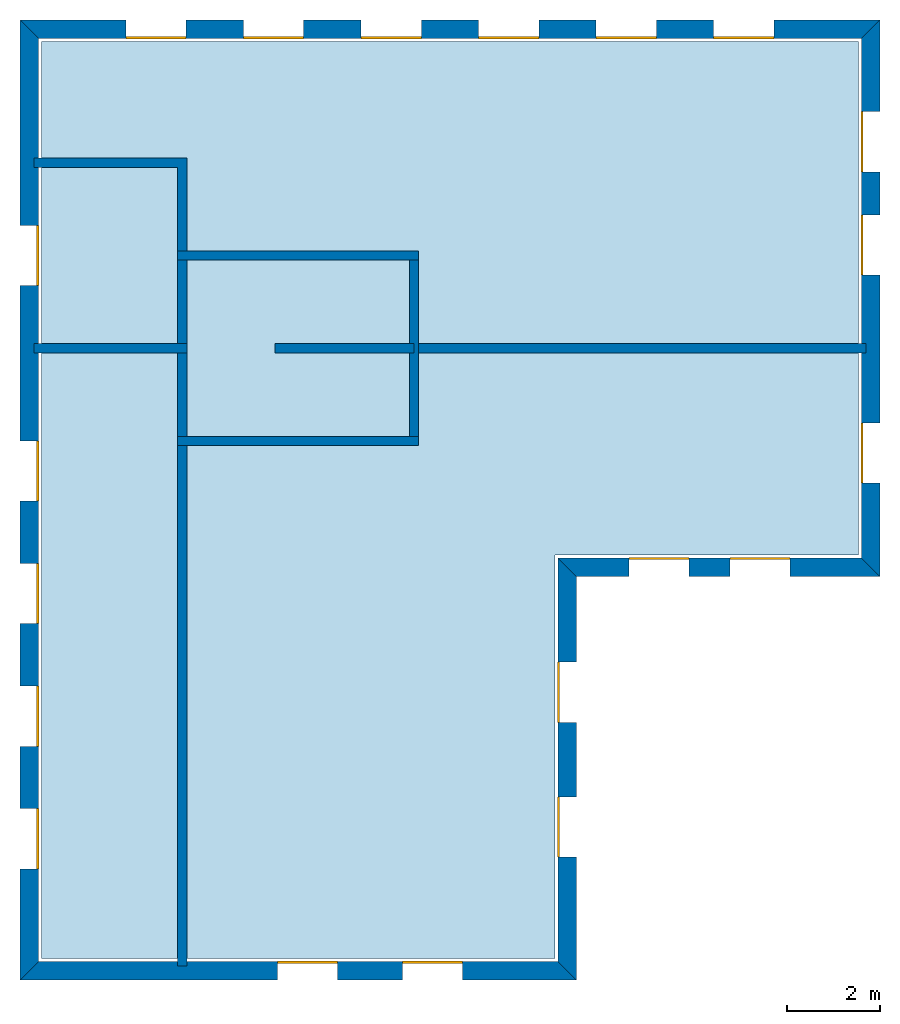
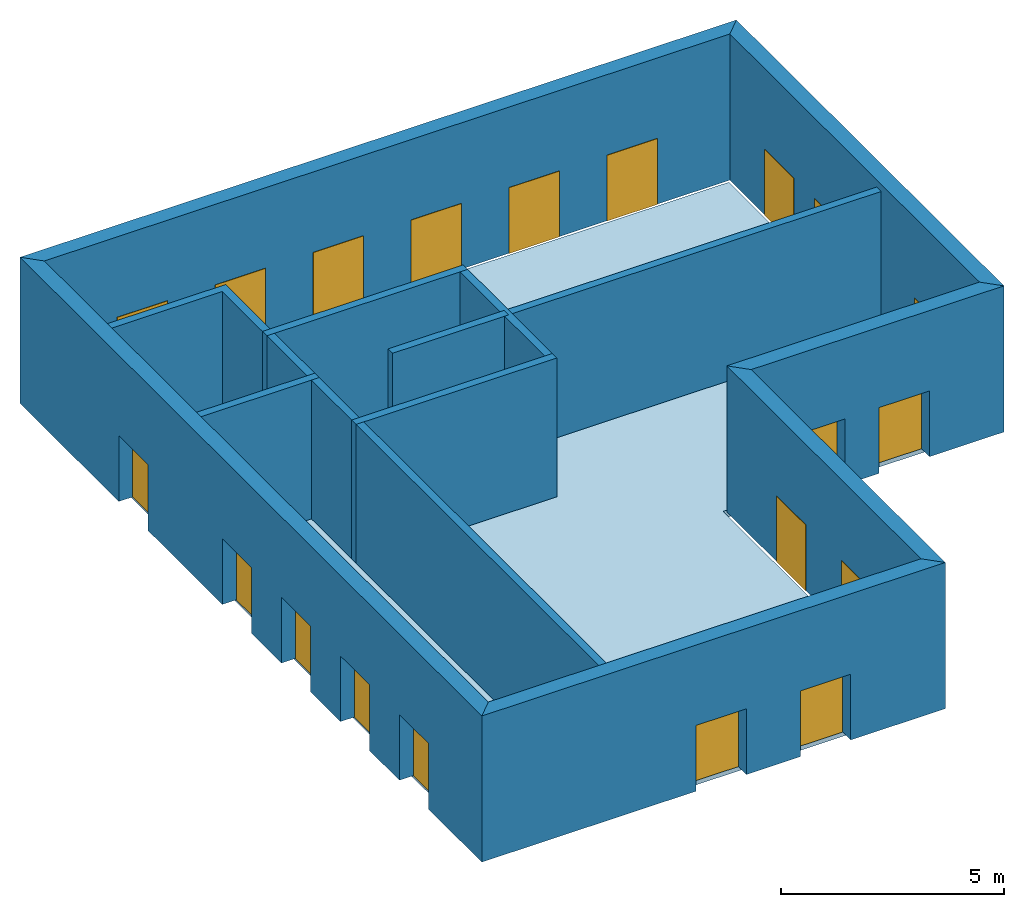
# One storey: 20 windows, 15 walls, 1 slab, 20 openings.
"""IFC4 building model written with IfcOpenShell, lengths in metres."""

from ifc_helpers import new_model, si_unit, origin_with_axes, place, context, subcontext, project, spatial, line, indexed_curve, outline, extrude, element, fill, save


model = new_model("IFC4")

# Units and contexts
model_context = context("Model", 3, precision=1e-05, world=origin_with_axes())
body_context = subcontext(model_context, "Body", "Model", "MODEL_VIEW")
ifc_project = project(units=[si_unit("AREAUNIT", "SQUARE_METRE"), si_unit("VOLUMEUNIT", "CUBIC_METRE"), si_unit("LENGTHUNIT", "METRE")], contexts=[model_context])

# Site, building, storey
site = spatial("IfcSite", under=ifc_project)
building = spatial("IfcBuilding", under=site, Name="Building 1")
storey_placement = place(None, origin_with_axes())
storey = spatial("IfcBuildingStorey", under=building, at=storey_placement, Name="01 Storey")

# Slab
slab_placement = place(storey_placement, origin_with_axes())
element("IfcSlab", 1, at=slab_placement, inside=storey, Name="Slab", context=body_context, shape_type="SweptSolid", body=[
    extrude(outline(indexed_curve([(15.533354, 14.715575), (22.079464, 14.715575), (22.079464, 25.795575), (4.453354, 25.795575), (4.453354, 6.0082), (15.533354, 6.0082)], segments=[line(1, 2), line(2, 3), line(3, 4), line(4, 5), line(5, 6)])), origin_with_axes(), (0.0, 0.0, -1.0), 0.2),
])

# Walls
wall_1_placement = place(storey_placement, origin_with_axes())
element("IfcWall", 2, at=wall_1_placement, inside=storey, Name="Wall", context=body_context, shape_type="SweptSolid", body=[
    extrude(outline(indexed_curve([(22.239464, 19.274943), (12.393354, 19.274943), (12.393354, 19.074943), (22.239464, 19.074943)], segments=[line(1, 2), line(2, 3), line(3, 4)])), origin_with_axes(), (0.0, 0.0, 1.0), 3.8),
])
wall_2_placement = place(storey_placement, origin_with_axes())
element("IfcWall", 3, at=wall_2_placement, inside=storey, Name="Wall", context=body_context, shape_type="SweptSolid", body=[
    extrude(outline(indexed_curve([(7.593354, 17.274943), (7.393354, 17.274943), (7.393354, 5.8482), (7.593354, 5.8482)], segments=[line(1, 2), line(2, 3), line(3, 4)])), origin_with_axes(), (0.0, 0.0, 1.0), 3.8),
])
wall_3_placement = place(storey_placement, origin_with_axes())
element("IfcWall", 4, at=wall_3_placement, inside=storey, Name="Wall", context=body_context, shape_type="SweptSolid", body=[
    extrude(outline(indexed_curve([(7.593354, 19.274943), (4.293354, 19.274943), (4.293354, 19.074943), (7.593354, 19.074943)], segments=[line(1, 2), line(2, 3), line(3, 4)])), origin_with_axes(), (0.0, 0.0, 1.0), 3.8),
])
wall_4_placement = place(storey_placement, origin_with_axes())
element("IfcWall", 5, at=wall_4_placement, inside=storey, Name="Wall", context=body_context, shape_type="SweptSolid", body=[
    extrude(outline(indexed_curve([(7.593354, 23.274943), (4.293354, 23.274943), (4.293354, 23.074943), (7.393354, 23.074943), (7.393354, 21.074943), (7.593354, 21.074943)], segments=[line(1, 2), line(2, 3), line(3, 4), line(4, 5), line(5, 6)])), origin_with_axes(), (0.0, 0.0, 1.0), 3.8),
])

# Wall, openings, windows
wall_5_placement = place(storey_placement, origin_with_axes())
wall_5 = element("IfcWall", 6, at=wall_5_placement, inside=storey, Name="Facade", context=body_context, shape_type="SweptSolid", body=[
    extrude(outline(indexed_curve([(15.593354, 14.655575), (22.139464, 14.655575), (22.539464, 14.255575), (15.993354, 14.255575)], segments=[line(1, 2), line(2, 3), line(3, 4)])), origin_with_axes(), (0.0, 0.0, 1.0), 4.0),
])
opening_1_placement = place(wall_5_placement, origin_with_axes())
opening_1 = element("IfcOpeningElement", 7, at=opening_1_placement, cuts=wall_5, Name="Opening", context=body_context, shape_type="SweptSolid", body=[
    extrude(outline(indexed_curve([(17.1253906666667, 14.215575), (17.1253906666667, 14.715575), (18.4253906666667, 14.715575), (18.4253906666667, 14.215575)], segments=[line(1, 2), line(2, 3), line(3, 4)])), origin_with_axes(), (0.0, 0.0, 1.0), 1.8),
])
opening_2_placement = place(wall_5_placement, origin_with_axes())
opening_2 = element("IfcOpeningElement", 8, at=opening_2_placement, cuts=wall_5, Name="Opening", context=body_context, shape_type="SweptSolid", body=[
    extrude(outline(indexed_curve([(19.3074273333333, 14.215575), (19.3074273333333, 14.715575), (20.6074273333333, 14.715575), (20.6074273333333, 14.215575)], segments=[line(1, 2), line(2, 3), line(3, 4)])), origin_with_axes(), (0.0, 0.0, 1.0), 1.8),
])
window_1_placement = place(storey_placement, origin_with_axes())
window_1 = element("IfcWindow", 9, at=window_1_placement, inside=storey, Name="Window", PredefinedType="WINDOW", context=body_context, shape_type="SweptSolid", body=[
    extrude(outline(indexed_curve([(17.1253906666667, 14.615575), (17.1253906666667, 14.665575), (18.4253906666667, 14.665575), (18.4253906666667, 14.615575)], segments=[line(1, 2), line(2, 3), line(3, 4)])), origin_with_axes(), (0.0, 0.0, 1.0), 1.8),
])
fill(opening_1, window_1)
window_2_placement = place(storey_placement, origin_with_axes())
window_2 = element("IfcWindow", 10, at=window_2_placement, inside=storey, Name="Window", PredefinedType="WINDOW", context=body_context, shape_type="SweptSolid", body=[
    extrude(outline(indexed_curve([(19.3074273333333, 14.615575), (19.3074273333333, 14.665575), (20.6074273333333, 14.665575), (20.6074273333333, 14.615575)], segments=[line(1, 2), line(2, 3), line(3, 4)])), origin_with_axes(), (0.0, 0.0, 1.0), 1.8),
])
fill(opening_2, window_2)

wall_6_placement = place(storey_placement, origin_with_axes())
wall_6 = element("IfcWall", 11, at=wall_6_placement, inside=storey, Name="Facade", context=body_context, shape_type="SweptSolid", body=[
    extrude(outline(indexed_curve([(22.139464, 14.655575), (22.139464, 25.855575), (22.539464, 26.255575), (22.539464, 14.255575)], segments=[line(1, 2), line(2, 3), line(3, 4)])), origin_with_axes(), (0.0, 0.0, 1.0), 4.0),
])
opening_3_placement = place(wall_6_placement, origin_with_axes())
opening_3 = element("IfcOpeningElement", 12, at=opening_3_placement, cuts=wall_6, Name="Opening", context=body_context, shape_type="SweptSolid", body=[
    extrude(outline(indexed_curve([(22.579464, 16.265259), (22.079464, 16.265259), (22.079464, 17.565259), (22.579464, 17.565259)], segments=[line(1, 2), line(2, 3), line(3, 4)])), origin_with_axes(), (0.0, 0.0, 1.0), 1.8),
])
opening_4_placement = place(wall_6_placement, origin_with_axes())
opening_4 = element("IfcOpeningElement", 13, at=opening_4_placement, cuts=wall_6, Name="Opening", context=body_context, shape_type="SweptSolid", body=[
    extrude(outline(indexed_curve([(22.579464, 20.7518203333333), (22.079464, 20.7518203333333), (22.079464, 22.0518203333333), (22.579464, 22.0518203333333)], segments=[line(1, 2), line(2, 3), line(3, 4)])), origin_with_axes(), (0.0, 0.0, 1.0), 1.8),
])
opening_5_placement = place(wall_6_placement, origin_with_axes())
opening_5 = element("IfcOpeningElement", 14, at=opening_5_placement, cuts=wall_6, Name="Opening", context=body_context, shape_type="SweptSolid", body=[
    extrude(outline(indexed_curve([(22.579464, 22.9786976666667), (22.079464, 22.9786976666667), (22.079464, 24.2786976666667), (22.579464, 24.2786976666667)], segments=[line(1, 2), line(2, 3), line(3, 4)])), origin_with_axes(), (0.0, 0.0, 1.0), 1.8),
])
window_3_placement = place(storey_placement, origin_with_axes())
window_3 = element("IfcWindow", 15, at=window_3_placement, inside=storey, Name="Window", PredefinedType="WINDOW", context=body_context, shape_type="SweptSolid", body=[
    extrude(outline(indexed_curve([(22.179464, 16.265259), (22.129464, 16.265259), (22.129464, 17.565259), (22.179464, 17.565259)], segments=[line(1, 2), line(2, 3), line(3, 4)])), origin_with_axes(), (0.0, 0.0, 1.0), 1.8),
])
fill(opening_3, window_3)
window_4_placement = place(storey_placement, origin_with_axes())
window_4 = element("IfcWindow", 16, at=window_4_placement, inside=storey, Name="Window", PredefinedType="WINDOW", context=body_context, shape_type="SweptSolid", body=[
    extrude(outline(indexed_curve([(22.179464, 20.7518203333333), (22.129464, 20.7518203333333), (22.129464, 22.0518203333333), (22.179464, 22.0518203333333)], segments=[line(1, 2), line(2, 3), line(3, 4)])), origin_with_axes(), (0.0, 0.0, 1.0), 1.8),
])
fill(opening_4, window_4)
window_5_placement = place(storey_placement, origin_with_axes())
window_5 = element("IfcWindow", 17, at=window_5_placement, inside=storey, Name="Window", PredefinedType="WINDOW", context=body_context, shape_type="SweptSolid", body=[
    extrude(outline(indexed_curve([(22.179464, 22.9786976666667), (22.129464, 22.9786976666667), (22.129464, 24.2786976666667), (22.179464, 24.2786976666667)], segments=[line(1, 2), line(2, 3), line(3, 4)])), origin_with_axes(), (0.0, 0.0, 1.0), 1.8),
])
fill(opening_5, window_5)

wall_7_placement = place(storey_placement, origin_with_axes())
wall_7 = element("IfcWall", 18, at=wall_7_placement, inside=storey, Name="Facade", context=body_context, shape_type="SweptSolid", body=[
    extrude(outline(indexed_curve([(22.139464, 25.855575), (4.393354, 25.855575), (3.993354, 26.255575), (22.539464, 26.255575)], segments=[line(1, 2), line(2, 3), line(3, 4)])), origin_with_axes(), (0.0, 0.0, 1.0), 4.0),
])
opening_6_placement = place(wall_7_placement, origin_with_axes())
opening_6 = element("IfcOpeningElement", 19, at=opening_6_placement, cuts=wall_7, Name="Opening", context=body_context, shape_type="SweptSolid", body=[
    extrude(outline(indexed_curve([(20.2543054285714, 26.295575), (20.2543054285714, 25.795575), (18.9543054285714, 25.795575), (18.9543054285714, 26.295575)], segments=[line(1, 2), line(2, 3), line(3, 4)])), origin_with_axes(), (0.0, 0.0, 1.0), 1.8),
])
opening_7_placement = place(wall_7_placement, origin_with_axes())
opening_7 = element("IfcOpeningElement", 20, at=opening_7_placement, cuts=wall_7, Name="Opening", context=body_context, shape_type="SweptSolid", body=[
    extrude(outline(indexed_curve([(17.7191468571429, 26.295575), (17.7191468571429, 25.795575), (16.4191468571429, 25.795575), (16.4191468571429, 26.295575)], segments=[line(1, 2), line(2, 3), line(3, 4)])), origin_with_axes(), (0.0, 0.0, 1.0), 1.8),
])
opening_8_placement = place(wall_7_placement, origin_with_axes())
opening_8 = element("IfcOpeningElement", 21, at=opening_8_placement, cuts=wall_7, Name="Opening", context=body_context, shape_type="SweptSolid", body=[
    extrude(outline(indexed_curve([(15.1839882857143, 26.295575), (15.1839882857143, 25.795575), (13.8839882857143, 25.795575), (13.8839882857143, 26.295575)], segments=[line(1, 2), line(2, 3), line(3, 4)])), origin_with_axes(), (0.0, 0.0, 1.0), 1.8),
])
opening_9_placement = place(wall_7_placement, origin_with_axes())
opening_9 = element("IfcOpeningElement", 22, at=opening_9_placement, cuts=wall_7, Name="Opening", context=body_context, shape_type="SweptSolid", body=[
    extrude(outline(indexed_curve([(12.6488297142857, 26.295575), (12.6488297142857, 25.795575), (11.3488297142857, 25.795575), (11.3488297142857, 26.295575)], segments=[line(1, 2), line(2, 3), line(3, 4)])), origin_with_axes(), (0.0, 0.0, 1.0), 1.8),
])
opening_10_placement = place(wall_7_placement, origin_with_axes())
opening_10 = element("IfcOpeningElement", 23, at=opening_10_placement, cuts=wall_7, Name="Opening", context=body_context, shape_type="SweptSolid", body=[
    extrude(outline(indexed_curve([(10.1136711428571, 26.295575), (10.1136711428571, 25.795575), (8.81367114285714, 25.795575), (8.81367114285714, 26.295575)], segments=[line(1, 2), line(2, 3), line(3, 4)])), origin_with_axes(), (0.0, 0.0, 1.0), 1.8),
])
opening_11_placement = place(wall_7_placement, origin_with_axes())
opening_11 = element("IfcOpeningElement", 24, at=opening_11_placement, cuts=wall_7, Name="Opening", context=body_context, shape_type="SweptSolid", body=[
    extrude(outline(indexed_curve([(7.57851257142857, 26.295575), (7.57851257142857, 25.795575), (6.27851257142857, 25.795575), (6.27851257142857, 26.295575)], segments=[line(1, 2), line(2, 3), line(3, 4)])), origin_with_axes(), (0.0, 0.0, 1.0), 1.8),
])
window_6_placement = place(storey_placement, origin_with_axes())
window_6 = element("IfcWindow", 25, at=window_6_placement, inside=storey, Name="Window", PredefinedType="WINDOW", context=body_context, shape_type="SweptSolid", body=[
    extrude(outline(indexed_curve([(20.2543054285714, 25.895575), (20.2543054285714, 25.845575), (18.9543054285714, 25.845575), (18.9543054285714, 25.895575)], segments=[line(1, 2), line(2, 3), line(3, 4)])), origin_with_axes(), (0.0, 0.0, 1.0), 1.8),
])
fill(opening_6, window_6)
window_7_placement = place(storey_placement, origin_with_axes())
window_7 = element("IfcWindow", 26, at=window_7_placement, inside=storey, Name="Window", PredefinedType="WINDOW", context=body_context, shape_type="SweptSolid", body=[
    extrude(outline(indexed_curve([(17.7191468571429, 25.895575), (17.7191468571429, 25.845575), (16.4191468571429, 25.845575), (16.4191468571429, 25.895575)], segments=[line(1, 2), line(2, 3), line(3, 4)])), origin_with_axes(), (0.0, 0.0, 1.0), 1.8),
])
fill(opening_7, window_7)
window_8_placement = place(storey_placement, origin_with_axes())
window_8 = element("IfcWindow", 27, at=window_8_placement, inside=storey, Name="Window", PredefinedType="WINDOW", context=body_context, shape_type="SweptSolid", body=[
    extrude(outline(indexed_curve([(15.1839882857143, 25.895575), (15.1839882857143, 25.845575), (13.8839882857143, 25.845575), (13.8839882857143, 25.895575)], segments=[line(1, 2), line(2, 3), line(3, 4)])), origin_with_axes(), (0.0, 0.0, 1.0), 1.8),
])
fill(opening_8, window_8)
window_9_placement = place(storey_placement, origin_with_axes())
window_9 = element("IfcWindow", 28, at=window_9_placement, inside=storey, Name="Window", PredefinedType="WINDOW", context=body_context, shape_type="SweptSolid", body=[
    extrude(outline(indexed_curve([(12.6488297142857, 25.895575), (12.6488297142857, 25.845575), (11.3488297142857, 25.845575), (11.3488297142857, 25.895575)], segments=[line(1, 2), line(2, 3), line(3, 4)])), origin_with_axes(), (0.0, 0.0, 1.0), 1.8),
])
fill(opening_9, window_9)
window_10_placement = place(storey_placement, origin_with_axes())
window_10 = element("IfcWindow", 29, at=window_10_placement, inside=storey, Name="Window", PredefinedType="WINDOW", context=body_context, shape_type="SweptSolid", body=[
    extrude(outline(indexed_curve([(10.1136711428571, 25.895575), (10.1136711428571, 25.845575), (8.81367114285714, 25.845575), (8.81367114285714, 25.895575)], segments=[line(1, 2), line(2, 3), line(3, 4)])), origin_with_axes(), (0.0, 0.0, 1.0), 1.8),
])
fill(opening_10, window_10)
window_11_placement = place(storey_placement, origin_with_axes())
window_11 = element("IfcWindow", 30, at=window_11_placement, inside=storey, Name="Window", PredefinedType="WINDOW", context=body_context, shape_type="SweptSolid", body=[
    extrude(outline(indexed_curve([(7.57851257142857, 25.895575), (7.57851257142857, 25.845575), (6.27851257142857, 25.845575), (6.27851257142857, 25.895575)], segments=[line(1, 2), line(2, 3), line(3, 4)])), origin_with_axes(), (0.0, 0.0, 1.0), 1.8),
])
fill(opening_11, window_11)

wall_8_placement = place(storey_placement, origin_with_axes())
wall_8 = element("IfcWall", 31, at=wall_8_placement, inside=storey, Name="Facade", context=body_context, shape_type="SweptSolid", body=[
    extrude(outline(indexed_curve([(4.393354, 25.855575), (4.393354, 5.9482), (3.993354, 5.5482), (3.993354, 26.255575)], segments=[line(1, 2), line(2, 3), line(3, 4)])), origin_with_axes(), (0.0, 0.0, 1.0), 4.0),
])
opening_12_placement = place(wall_8_placement, origin_with_axes())
opening_12 = element("IfcOpeningElement", 32, at=opening_12_placement, cuts=wall_8, Name="Opening", context=body_context, shape_type="SweptSolid", body=[
    extrude(outline(indexed_curve([(3.953354, 17.1795944), (4.453354, 17.1795944), (4.453354, 15.8795944), (3.953354, 15.8795944)], segments=[line(1, 2), line(2, 3), line(3, 4)])), origin_with_axes(), (0.0, 0.0, 1.0), 1.8),
])
opening_13_placement = place(wall_8_placement, origin_with_axes())
opening_13 = element("IfcOpeningElement", 33, at=opening_13_placement, cuts=wall_8, Name="Opening", context=body_context, shape_type="SweptSolid", body=[
    extrude(outline(indexed_curve([(3.953354, 14.5342458), (4.453354, 14.5342458), (4.453354, 13.2342458), (3.953354, 13.2342458)], segments=[line(1, 2), line(2, 3), line(3, 4)])), origin_with_axes(), (0.0, 0.0, 1.0), 1.8),
])
opening_14_placement = place(wall_8_placement, origin_with_axes())
opening_14 = element("IfcOpeningElement", 34, at=opening_14_placement, cuts=wall_8, Name="Opening", context=body_context, shape_type="SweptSolid", body=[
    extrude(outline(indexed_curve([(3.953354, 11.8888972), (4.453354, 11.8888972), (4.453354, 10.5888972), (3.953354, 10.5888972)], segments=[line(1, 2), line(2, 3), line(3, 4)])), origin_with_axes(), (0.0, 0.0, 1.0), 1.8),
])
opening_15_placement = place(wall_8_placement, origin_with_axes())
opening_15 = element("IfcOpeningElement", 35, at=opening_15_placement, cuts=wall_8, Name="Opening", context=body_context, shape_type="SweptSolid", body=[
    extrude(outline(indexed_curve([(3.953354, 9.2435486), (4.453354, 9.2435486), (4.453354, 7.9435486), (3.953354, 7.9435486)], segments=[line(1, 2), line(2, 3), line(3, 4)])), origin_with_axes(), (0.0, 0.0, 1.0), 1.8),
])
opening_16_placement = place(wall_8_placement, origin_with_axes())
opening_16 = element("IfcOpeningElement", 36, at=opening_16_placement, cuts=wall_8, Name="Opening", context=body_context, shape_type="SweptSolid", body=[
    extrude(outline(indexed_curve([(3.953354, 21.824943), (4.453354, 21.824943), (4.453354, 20.524943), (3.953354, 20.524943)], segments=[line(1, 2), line(2, 3), line(3, 4)])), origin_with_axes(), (0.0, 0.0, 1.0), 1.8),
])
window_12_placement = place(storey_placement, origin_with_axes())
window_12 = element("IfcWindow", 37, at=window_12_placement, inside=storey, Name="Window", PredefinedType="WINDOW", context=body_context, shape_type="SweptSolid", body=[
    extrude(outline(indexed_curve([(4.353354, 17.1795944), (4.403354, 17.1795944), (4.403354, 15.8795944), (4.353354, 15.8795944)], segments=[line(1, 2), line(2, 3), line(3, 4)])), origin_with_axes(), (0.0, 0.0, 1.0), 1.8),
])
fill(opening_12, window_12)
window_13_placement = place(storey_placement, origin_with_axes())
window_13 = element("IfcWindow", 38, at=window_13_placement, inside=storey, Name="Window", PredefinedType="WINDOW", context=body_context, shape_type="SweptSolid", body=[
    extrude(outline(indexed_curve([(4.353354, 14.5342458), (4.403354, 14.5342458), (4.403354, 13.2342458), (4.353354, 13.2342458)], segments=[line(1, 2), line(2, 3), line(3, 4)])), origin_with_axes(), (0.0, 0.0, 1.0), 1.8),
])
fill(opening_13, window_13)
window_14_placement = place(storey_placement, origin_with_axes())
window_14 = element("IfcWindow", 39, at=window_14_placement, inside=storey, Name="Window", PredefinedType="WINDOW", context=body_context, shape_type="SweptSolid", body=[
    extrude(outline(indexed_curve([(4.353354, 11.8888972), (4.403354, 11.8888972), (4.403354, 10.5888972), (4.353354, 10.5888972)], segments=[line(1, 2), line(2, 3), line(3, 4)])), origin_with_axes(), (0.0, 0.0, 1.0), 1.8),
])
fill(opening_14, window_14)
window_15_placement = place(storey_placement, origin_with_axes())
window_15 = element("IfcWindow", 40, at=window_15_placement, inside=storey, Name="Window", PredefinedType="WINDOW", context=body_context, shape_type="SweptSolid", body=[
    extrude(outline(indexed_curve([(4.353354, 9.2435486), (4.403354, 9.2435486), (4.403354, 7.9435486), (4.353354, 7.9435486)], segments=[line(1, 2), line(2, 3), line(3, 4)])), origin_with_axes(), (0.0, 0.0, 1.0), 1.8),
])
fill(opening_15, window_15)
window_16_placement = place(storey_placement, origin_with_axes())
window_16 = element("IfcWindow", 41, at=window_16_placement, inside=storey, Name="Window", PredefinedType="WINDOW", context=body_context, shape_type="SweptSolid", body=[
    extrude(outline(indexed_curve([(4.353354, 21.824943), (4.403354, 21.824943), (4.403354, 20.524943), (4.353354, 20.524943)], segments=[line(1, 2), line(2, 3), line(3, 4)])), origin_with_axes(), (0.0, 0.0, 1.0), 1.8),
])
fill(opening_16, window_16)

wall_9_placement = place(storey_placement, origin_with_axes())
wall_9 = element("IfcWall", 42, at=wall_9_placement, inside=storey, Name="Facade", context=body_context, shape_type="SweptSolid", body=[
    extrude(outline(indexed_curve([(4.393354, 5.9482), (15.593354, 5.9482), (15.993354, 5.5482), (3.993354, 5.5482)], segments=[line(1, 2), line(2, 3), line(3, 4)])), origin_with_axes(), (0.0, 0.0, 1.0), 4.0),
])
opening_17_placement = place(wall_9_placement, origin_with_axes())
opening_17 = element("IfcOpeningElement", 43, at=opening_17_placement, cuts=wall_9, Name="Opening", context=body_context, shape_type="SweptSolid", body=[
    extrude(outline(indexed_curve([(9.543354, 5.5082), (9.543354, 6.0082), (10.843354, 6.0082), (10.843354, 5.5082)], segments=[line(1, 2), line(2, 3), line(3, 4)])), origin_with_axes(), (0.0, 0.0, 1.0), 1.8),
])
opening_18_placement = place(wall_9_placement, origin_with_axes())
opening_18 = element("IfcOpeningElement", 44, at=opening_18_placement, cuts=wall_9, Name="Opening", context=body_context, shape_type="SweptSolid", body=[
    extrude(outline(indexed_curve([(12.243354, 5.5082), (12.243354, 6.0082), (13.543354, 6.0082), (13.543354, 5.5082)], segments=[line(1, 2), line(2, 3), line(3, 4)])), origin_with_axes(), (0.0, 0.0, 1.0), 1.8),
])
window_17_placement = place(storey_placement, origin_with_axes())
window_17 = element("IfcWindow", 45, at=window_17_placement, inside=storey, Name="Window", PredefinedType="WINDOW", context=body_context, shape_type="SweptSolid", body=[
    extrude(outline(indexed_curve([(9.543354, 5.9082), (9.543354, 5.9582), (10.843354, 5.9582), (10.843354, 5.9082)], segments=[line(1, 2), line(2, 3), line(3, 4)])), origin_with_axes(), (0.0, 0.0, 1.0), 1.8),
])
fill(opening_17, window_17)
window_18_placement = place(storey_placement, origin_with_axes())
window_18 = element("IfcWindow", 46, at=window_18_placement, inside=storey, Name="Window", PredefinedType="WINDOW", context=body_context, shape_type="SweptSolid", body=[
    extrude(outline(indexed_curve([(12.243354, 5.9082), (12.243354, 5.9582), (13.543354, 5.9582), (13.543354, 5.9082)], segments=[line(1, 2), line(2, 3), line(3, 4)])), origin_with_axes(), (0.0, 0.0, 1.0), 1.8),
])
fill(opening_18, window_18)

wall_10_placement = place(storey_placement, origin_with_axes())
wall_10 = element("IfcWall", 47, at=wall_10_placement, inside=storey, Name="Facade", context=body_context, shape_type="SweptSolid", body=[
    extrude(outline(indexed_curve([(15.593354, 5.9482), (15.593354, 14.655575), (15.993354, 14.255575), (15.993354, 5.5482)], segments=[line(1, 2), line(2, 3), line(3, 4)])), origin_with_axes(), (0.0, 0.0, 1.0), 4.0),
])
opening_19_placement = place(wall_10_placement, origin_with_axes())
opening_19 = element("IfcOpeningElement", 48, at=opening_19_placement, cuts=wall_10, Name="Opening", context=body_context, shape_type="SweptSolid", body=[
    extrude(outline(indexed_curve([(16.033354, 8.20065833333333), (15.533354, 8.20065833333333), (15.533354, 9.50065833333333), (16.033354, 9.50065833333333)], segments=[line(1, 2), line(2, 3), line(3, 4)])), origin_with_axes(), (0.0, 0.0, 1.0), 1.8),
])
opening_20_placement = place(wall_10_placement, origin_with_axes())
opening_20 = element("IfcOpeningElement", 49, at=opening_20_placement, cuts=wall_10, Name="Opening", context=body_context, shape_type="SweptSolid", body=[
    extrude(outline(indexed_curve([(16.033354, 11.1031166666667), (15.533354, 11.1031166666667), (15.533354, 12.4031166666667), (16.033354, 12.4031166666667)], segments=[line(1, 2), line(2, 3), line(3, 4)])), origin_with_axes(), (0.0, 0.0, 1.0), 1.8),
])
window_19_placement = place(storey_placement, origin_with_axes())
window_19 = element("IfcWindow", 50, at=window_19_placement, inside=storey, Name="Window", PredefinedType="WINDOW", context=body_context, shape_type="SweptSolid", body=[
    extrude(outline(indexed_curve([(15.633354, 8.20065833333333), (15.583354, 8.20065833333333), (15.583354, 9.50065833333333), (15.633354, 9.50065833333333)], segments=[line(1, 2), line(2, 3), line(3, 4)])), origin_with_axes(), (0.0, 0.0, 1.0), 1.8),
])
fill(opening_19, window_19)
window_20_placement = place(storey_placement, origin_with_axes())
window_20 = element("IfcWindow", 51, at=window_20_placement, inside=storey, Name="Window", PredefinedType="WINDOW", context=body_context, shape_type="SweptSolid", body=[
    extrude(outline(indexed_curve([(15.633354, 11.1031166666667), (15.583354, 11.1031166666667), (15.583354, 12.4031166666667), (15.633354, 12.4031166666667)], segments=[line(1, 2), line(2, 3), line(3, 4)])), origin_with_axes(), (0.0, 0.0, 1.0), 1.8),
])
fill(opening_20, window_20)

# Walls
wall_11_placement = place(storey_placement, origin_with_axes())
element("IfcWall", 52, at=wall_11_placement, inside=storey, Name="CoreWall", context=body_context, shape_type="SweptSolid", body=[
    extrude(outline(indexed_curve([(12.593354, 21.274943), (7.393354, 21.274943), (7.393354, 21.074943), (12.593354, 21.074943)], segments=[line(1, 2), line(2, 3), line(3, 4)])), origin_with_axes(), (0.0, 0.0, 1.0), 3.8),
])
wall_12_placement = place(storey_placement, origin_with_axes())
element("IfcWall", 53, at=wall_12_placement, inside=storey, Name="CoreWall", context=body_context, shape_type="SweptSolid", body=[
    extrude(outline(indexed_curve([(7.393354, 17.074943), (12.593354, 17.074943), (12.593354, 17.274943), (7.393354, 17.274943)], segments=[line(1, 2), line(2, 3), line(3, 4)])), origin_with_axes(), (0.0, 0.0, 1.0), 3.8),
])
wall_13_placement = place(storey_placement, origin_with_axes())
element("IfcWall", 54, at=wall_13_placement, inside=storey, Name="CoreWall", context=body_context, shape_type="SweptSolid", body=[
    extrude(outline(indexed_curve([(7.593354, 17.274943), (7.593354, 21.074943), (7.393354, 21.074943), (7.393354, 17.274943)], segments=[line(1, 2), line(2, 3), line(3, 4)])), origin_with_axes(), (0.0, 0.0, 1.0), 3.8),
])
wall_14_placement = place(storey_placement, origin_with_axes())
element("IfcWall", 55, at=wall_14_placement, inside=storey, Name="CoreWall", context=body_context, shape_type="SweptSolid", body=[
    extrude(outline(indexed_curve([(12.393354, 21.074943), (12.393354, 17.274943), (12.593354, 17.274943), (12.593354, 21.074943)], segments=[line(1, 2), line(2, 3), line(3, 4)])), origin_with_axes(), (0.0, 0.0, 1.0), 3.8),
])
wall_15_placement = place(storey_placement, origin_with_axes())
element("IfcWall", 56, at=wall_15_placement, inside=storey, Name="CoreWall", context=body_context, shape_type="SweptSolid", body=[
    extrude(outline(indexed_curve([(12.493354, 19.274943), (9.493354, 19.274943), (9.493354, 19.074943), (12.493354, 19.074943)], segments=[line(1, 2), line(2, 3), line(3, 4)])), origin_with_axes(), (0.0, 0.0, 1.0), 3.8),
])

save(model, "model.ifc")
